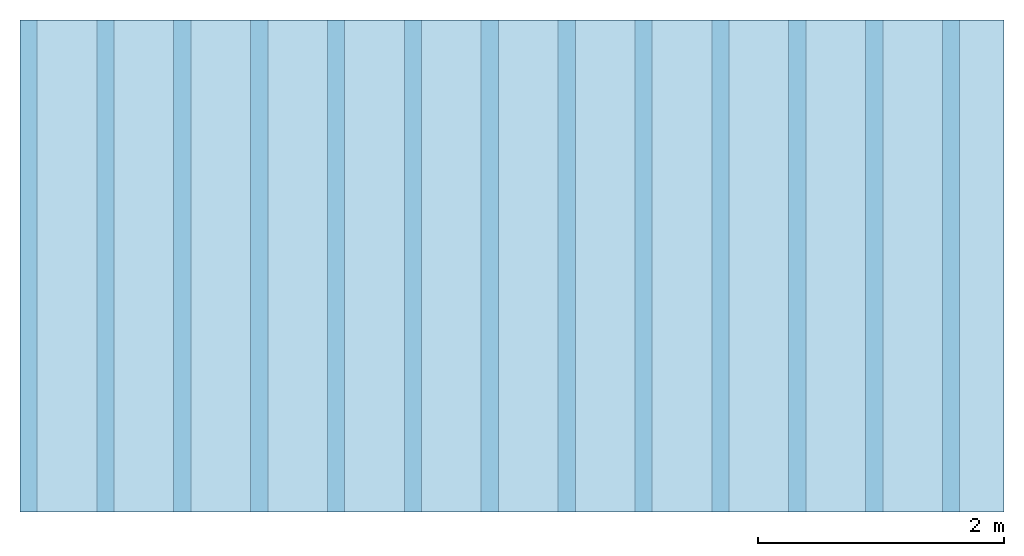
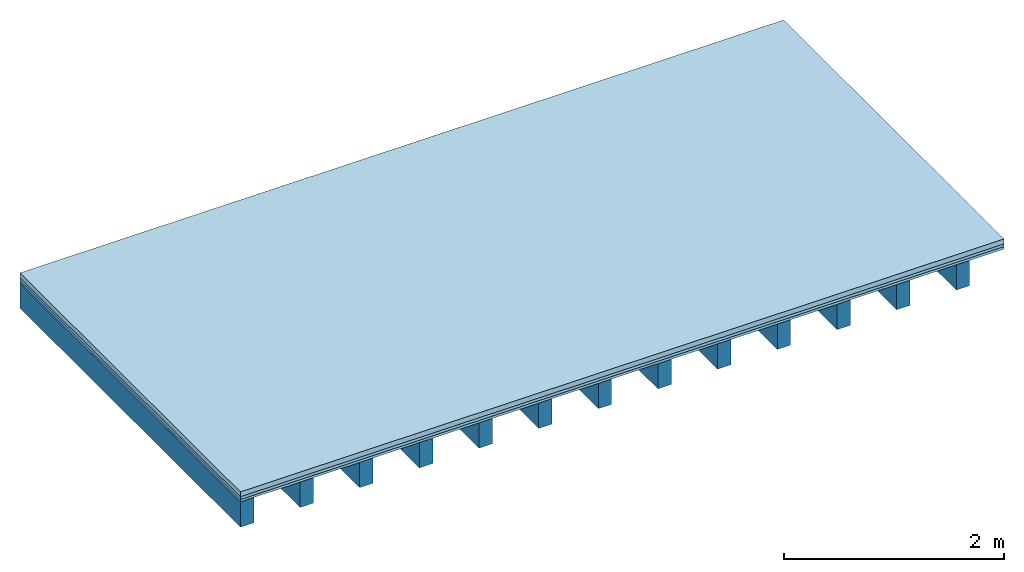
# One storey: 3 plates, 1 member, 1 element without a shape of its own.
"""IFC4 building model written with IfcOpenShell, lengths in metres."""

from ifc_helpers import new_model, si_unit, derived_unit, direction, frame, frame_2d, origin, origin_with_axes, place, context, project, spatial, rectangle, extrude, material, layer, layer_set, type_object, element, aggregate, save


model = new_model("IFC4")

# Units and contexts
plan_context = context("Plan", 3, precision=1e-05, world=origin(), true_north=direction((0.0, 1.0)))
model_context = context("Model", 3, precision=1e-05, world=origin(), true_north=direction((0.0, 1.0)))
ifc_project = project(units=[si_unit("LENGTHUNIT", "METRE"), derived_unit("SOUNDPRESSUREUNIT", [(si_unit("PRESSUREUNIT", "PASCAL", prefix="MICRO"), 0)]), si_unit("ENERGYUNIT", "JOULE", prefix="MEGA"), si_unit("MASSUNIT", "GRAM", prefix="KILO"), derived_unit("THERMALTRANSMITTANCEUNIT", [(si_unit("POWERUNIT", "WATT"), 1), (si_unit("AREAUNIT", "SQUARE_METRE"), -1), (si_unit("THERMODYNAMICTEMPERATUREUNIT", "KELVIN"), -1)]), derived_unit("AREADENSITYUNIT", [(si_unit("MASSUNIT", "GRAM", prefix="KILO"), 1), (si_unit("AREAUNIT", "SQUARE_METRE"), -1)]), derived_unit("USERDEFINED", [(si_unit("ENERGYUNIT", "JOULE", prefix="MEGA"), 1), (si_unit("AREAUNIT", "SQUARE_METRE"), -1)])], contexts=[plan_context, model_context])

# Site, building, storey
site = spatial("IfcSite", under=ifc_project)
building_placement = place(None, origin())
building = spatial("IfcBuilding", under=site, at=building_placement)
storey_placement = place(building_placement, origin())
storey = spatial("IfcBuildingStorey", under=building, at=storey_placement)

# Slab, member, plates
ifc_material_1 = material(Category="04.005")
ifc_layer_1 = layer(ifc_material_1, 0.055, Name="On-material")
ifc_material_2 = material()
ifc_layer_2 = layer(ifc_material_2, 0.03, Name="Impact sound insulation")
ifc_material_3 = material(Category="07.001")
ifc_layer_3 = layer(ifc_material_3, 0.027, Name="Sub-floor")
ifc_material_4 = material(Name="of the art")
ifc_layer_4 = layer(ifc_material_4, 0.0, Name="Bond")
ifc_layer_5 = layer(None, 0.28, Name="Supporting structure")
ifc_layer_set = layer_set([ifc_layer_1, ifc_layer_2, ifc_layer_3, ifc_layer_4, ifc_layer_5])
slab_type = type_object("IfcSlabType", Name="A0092", PredefinedType="NOTDEFINED", material=ifc_layer_set)
slab_placement = place(None, frame((0.0, 0.0, 0.0), z_axis=(0.0, 0.0, -1.0), x_axis=(1.0, 0.0, 0.0)))
slab = element("IfcSlab", 1, at=slab_placement, inside=storey, type_object=slab_type, material=ifc_layer_set, Name="Slab #1")
ifc_material_5 = material()
member_placement = place(slab_placement, origin())
member = element("IfcMember", 2, at=member_placement, material=ifc_material_5, Name="Supporting structure", context=plan_context, shape_type="SweptSolid", body=[
    extrude(rectangle(XDim=0.14, YDim=0.28, at=frame_2d((0.07, 0.14), x_axis=(1.0, 0.0))), frame((0.0, 4.0, 0.112), z_axis=(0.0, -1.0, 0.0), x_axis=(1.0, 0.0, 0.0)), (0.0, 0.0, 1.0), 4.0),
    extrude(rectangle(XDim=0.14, YDim=0.28, at=frame_2d((0.07, 0.14), x_axis=(1.0, 0.0))), frame((0.625, 4.0, 0.112), z_axis=(0.0, -1.0, 0.0), x_axis=(1.0, 0.0, 0.0)), (0.0, 0.0, 1.0), 4.0),
    extrude(rectangle(XDim=0.14, YDim=0.28, at=frame_2d((0.07, 0.14), x_axis=(1.0, 0.0))), frame((1.25, 4.0, 0.112), z_axis=(0.0, -1.0, 0.0), x_axis=(1.0, 0.0, 0.0)), (0.0, 0.0, 1.0), 4.0),
    extrude(rectangle(XDim=0.14, YDim=0.28, at=frame_2d((0.07, 0.14), x_axis=(1.0, 0.0))), frame((1.875, 4.0, 0.112), z_axis=(0.0, -1.0, 0.0), x_axis=(1.0, 0.0, 0.0)), (0.0, 0.0, 1.0), 4.0),
    extrude(rectangle(XDim=0.14, YDim=0.28, at=frame_2d((0.07, 0.14), x_axis=(1.0, 0.0))), frame((2.5, 4.0, 0.112), z_axis=(0.0, -1.0, 0.0), x_axis=(1.0, 0.0, 0.0)), (0.0, 0.0, 1.0), 4.0),
    extrude(rectangle(XDim=0.14, YDim=0.28, at=frame_2d((0.07, 0.14), x_axis=(1.0, 0.0))), frame((3.125, 4.0, 0.112), z_axis=(0.0, -1.0, 0.0), x_axis=(1.0, 0.0, 0.0)), (0.0, 0.0, 1.0), 4.0),
    extrude(rectangle(XDim=0.14, YDim=0.28, at=frame_2d((0.07, 0.14), x_axis=(1.0, 0.0))), frame((3.75, 4.0, 0.112), z_axis=(0.0, -1.0, 0.0), x_axis=(1.0, 0.0, 0.0)), (0.0, 0.0, 1.0), 4.0),
    extrude(rectangle(XDim=0.14, YDim=0.28, at=frame_2d((0.07, 0.14), x_axis=(1.0, 0.0))), frame((4.375, 4.0, 0.112), z_axis=(0.0, -1.0, 0.0), x_axis=(1.0, 0.0, 0.0)), (0.0, 0.0, 1.0), 4.0),
    extrude(rectangle(XDim=0.14, YDim=0.28, at=frame_2d((0.07, 0.14), x_axis=(1.0, 0.0))), frame((5.0, 4.0, 0.112), z_axis=(0.0, -1.0, 0.0), x_axis=(1.0, 0.0, 0.0)), (0.0, 0.0, 1.0), 4.0),
    extrude(rectangle(XDim=0.14, YDim=0.28, at=frame_2d((0.07, 0.14), x_axis=(1.0, 0.0))), frame((5.625, 4.0, 0.112), z_axis=(0.0, -1.0, 0.0), x_axis=(1.0, 0.0, 0.0)), (0.0, 0.0, 1.0), 4.0),
    extrude(rectangle(XDim=0.14, YDim=0.28, at=frame_2d((0.07, 0.14), x_axis=(1.0, 0.0))), frame((6.25, 4.0, 0.112), z_axis=(0.0, -1.0, 0.0), x_axis=(1.0, 0.0, 0.0)), (0.0, 0.0, 1.0), 4.0),
    extrude(rectangle(XDim=0.14, YDim=0.28, at=frame_2d((0.07, 0.14), x_axis=(1.0, 0.0))), frame((6.875, 4.0, 0.112), z_axis=(0.0, -1.0, 0.0), x_axis=(1.0, 0.0, 0.0)), (0.0, 0.0, 1.0), 4.0),
    extrude(rectangle(XDim=0.14, YDim=0.28, at=frame_2d((0.07, 0.14), x_axis=(1.0, 0.0))), frame((7.5, 4.0, 0.112), z_axis=(0.0, -1.0, 0.0), x_axis=(1.0, 0.0, 0.0)), (0.0, 0.0, 1.0), 4.0),
])
plate_1_placement = place(slab_placement, origin())
plate_1 = element("IfcPlate", 3, at=plate_1_placement, material=ifc_material_1, Name="On-material", context=plan_context, shape_type="SweptSolid", body=[
    extrude(rectangle(XDim=8.0, YDim=4.0, at=frame_2d((4.0, 2.0), x_axis=(1.0, 0.0))), origin_with_axes(), (0.0, 0.0, 1.0), 0.055),
])
plate_2_placement = place(slab_placement, origin())
plate_2 = element("IfcPlate", 4, at=plate_2_placement, material=ifc_material_2, Name="Impact sound insulation", context=plan_context, shape_type="SweptSolid", body=[
    extrude(rectangle(XDim=8.0, YDim=4.0, at=frame_2d((4.0, 2.0), x_axis=(1.0, 0.0))), frame((0.0, 0.0, 0.055), z_axis=(0.0, 0.0, 1.0), x_axis=(1.0, 0.0, 0.0)), (0.0, 0.0, 1.0), 0.03),
])
plate_3_placement = place(slab_placement, origin())
plate_3 = element("IfcPlate", 5, at=plate_3_placement, material=ifc_material_3, Name="Sub-floor", context=plan_context, shape_type="SweptSolid", body=[
    extrude(rectangle(XDim=8.0, YDim=4.0, at=frame_2d((4.0, 2.0), x_axis=(1.0, 0.0))), frame((0.0, 0.0, 0.085), z_axis=(0.0, 0.0, 1.0), x_axis=(1.0, 0.0, 0.0)), (0.0, 0.0, 1.0), 0.027),
])
aggregate(slab, [plate_1, plate_2, plate_3, member])

save(model, "model.ifc")
